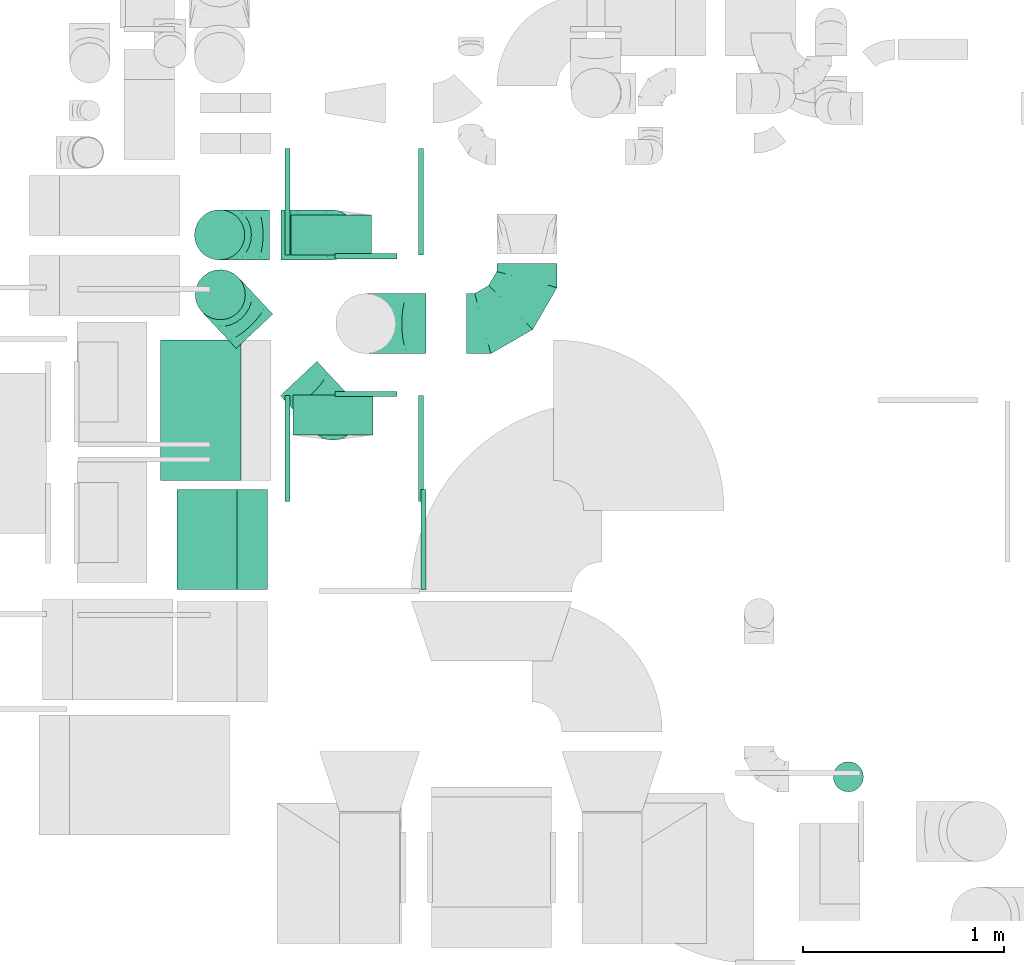
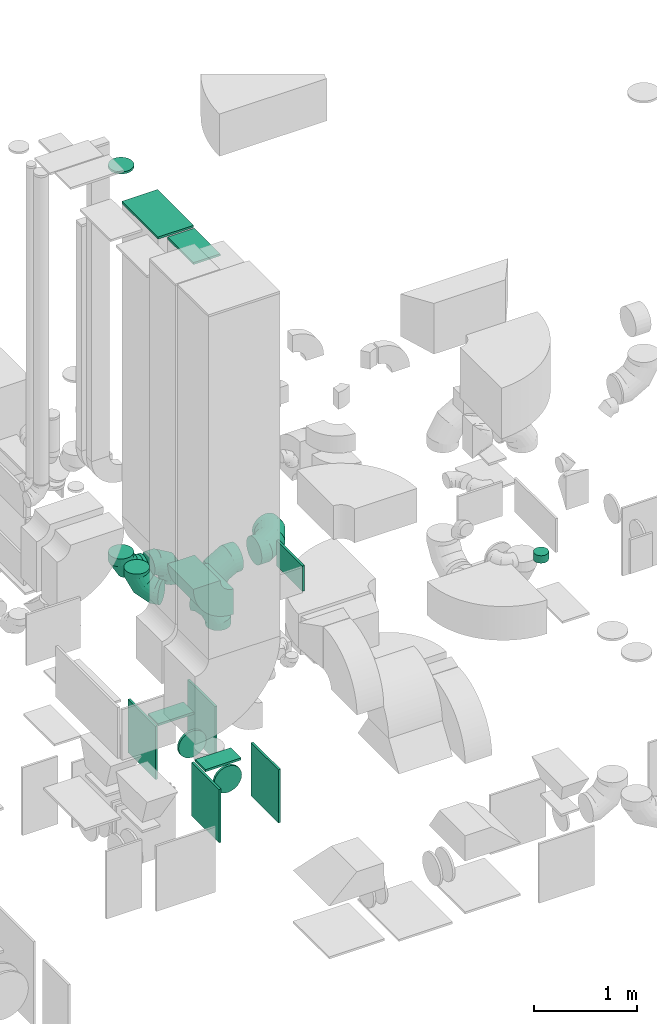
# One storey, part 21 of 59: 20 flow fittings.
"""IFC2X3 building model written with IfcOpenShell, lengths in millimetres."""

import ifcopenshell
import ifcopenshell.guid

model = None  # the IFC model being written
_history = None  # IfcOwnerHistory: only IFC2X3 demands one
_inside = {}  # id of a spatial element -> (the spatial element, [elements in it])
_under = {}  # id of a project, library or spatial element -> (it, [spatial elements below it])
_declared = {}  # id of a project -> (the project, [libraries it declares])
_typed = {}  # id of a type object -> (the type object, [elements of that type])
_made_of = {}  # id of a material, layer set ... -> (it, [elements and type objects made of it])


def new_model(schema):
    """Start an empty IFC model of exactly this schema.

    Asked for "IFC4X3", IfcOpenShell would pick the latest addendum, in which some entities
    have other attributes; the version numbers below select the first issue.
    IFC2X3 requires an IfcOwnerHistory on every rooted entity: one is made here for all.
    """
    global model, _history
    if schema == "IFC4X3":
        model = ifcopenshell.file(schema_version=(4, 3, 0, 0))
    else:
        model = ifcopenshell.file(schema=schema)
    _inside.clear()
    _under.clear()
    _declared.clear()
    _typed.clear()
    _made_of.clear()
    _history = None
    if model.schema == "IFC2X3":
        org = make("IfcOrganization", Name="unknown")
        user = make(
            "IfcPersonAndOrganization",
            ThePerson=make("IfcPerson", FamilyName="unknown"),
            TheOrganization=org,
        )
        app = make(
            "IfcApplication",
            ApplicationDeveloper=org,
            Version="unknown",
            ApplicationFullName="unknown",
            ApplicationIdentifier="unknown",
        )
        _history = make(
            "IfcOwnerHistory",
            OwningUser=user,
            OwningApplication=app,
            ChangeAction="ADDED",
            CreationDate=0,
        )
    return model


def make(cls, **values):
    """One entity of the class cls with the attributes given. An attribute that is None is left unset."""
    return model.create_entity(
        cls, **{name: value for name, value in values.items() if value is not None}
    )


def entity(cls, *values):
    """Any entity or typed value of the class cls, its attributes in the order of the schema. None: left unset."""
    e = model.create_entity(cls)
    for i, value in enumerate(values):
        if value is not None:
            e[i] = value
    return e


def rooted(cls, **values):
    """An entity with a GlobalId (a new one), such as an element, a storey or a relation."""
    return make(cls, GlobalId=ifcopenshell.guid.new(), OwnerHistory=_history, **values)


def si_unit(unit_type, name, prefix=None):
    """IfcSIUnit, for example si_unit("LENGTHUNIT", "METRE", prefix="MILLI")."""
    return make("IfcSIUnit", UnitType=unit_type, Prefix=prefix, Name=name)


def converted_unit(unit_type, name, factor, base, dimensions=None, offset=None):
    """IfcConversionBasedUnit, such as the inch: factor (a typed value) times the base unit."""
    return make(
        "IfcConversionBasedUnit"
        if offset is None
        else "IfcConversionBasedUnitWithOffset",
        ConversionOffset=offset,
        Dimensions=None
        if dimensions is None
        else entity("IfcDimensionalExponents", *dimensions),
        UnitType=unit_type,
        Name=name,
        ConversionFactor=make(
            "IfcMeasureWithUnit", ValueComponent=factor, UnitComponent=base
        ),
    )


def derived_unit(unit_type, elements):
    """IfcDerivedUnit: a product of units, each with its exponent."""
    return make(
        "IfcDerivedUnit",
        Elements=[
            make("IfcDerivedUnitElement", Unit=unit, Exponent=power)
            for unit, power in elements
        ],
        UnitType=unit_type,
    )


def assignment(units):
    """IfcUnitAssignment: the units of a project."""
    return None if units is None else make("IfcUnitAssignment", Units=units)


def point(xyz):
    """IfcCartesianPoint."""
    return None if xyz is None else make("IfcCartesianPoint", Coordinates=xyz)


def direction(xyz):
    """IfcDirection."""
    return None if xyz is None else make("IfcDirection", DirectionRatios=xyz)


def frame(location, z_axis=None, x_axis=None):
    """IfcAxis2Placement3D, a coordinate frame: its origin and axes. An axis left out is left unset."""
    return make(
        "IfcAxis2Placement3D",
        Location=point(location),
        Axis=direction(z_axis),
        RefDirection=direction(x_axis),
    )


def frame_2d(location, x_axis=None):
    """IfcAxis2Placement2D, a coordinate frame in the plane: its origin and x axis."""
    return make(
        "IfcAxis2Placement2D", Location=point(location), RefDirection=direction(x_axis)
    )


def origin():
    """The frame at (0, 0, 0) with its axes left unset."""
    return frame((0.0, 0.0, 0.0))


def origin_2d_with_axis():
    """The frame at (0, 0) in the plane with the x axis (1, 0) written out."""
    return frame_2d((0.0, 0.0), x_axis=(1.0, 0.0))


def place(relative_to, where):
    """IfcLocalPlacement: puts the frame where relative to a parent placement (None: the world)."""
    return make(
        "IfcLocalPlacement", PlacementRelTo=relative_to, RelativePlacement=where
    )


def context(
    kind, dimensions, precision=None, world=None, true_north=None, identifier=None
):
    """IfcGeometricRepresentationContext, for example the 3D "Model" context."""
    return make(
        "IfcGeometricRepresentationContext",
        ContextIdentifier=identifier,
        ContextType=kind,
        CoordinateSpaceDimension=dimensions,
        Precision=precision,
        WorldCoordinateSystem=world,
        TrueNorth=true_north,
    )


def subcontext(parent, identifier, kind, view, scale=None):
    """IfcGeometricRepresentationSubContext, for example "Body" below "Model"."""
    return make(
        "IfcGeometricRepresentationSubContext",
        ContextIdentifier=identifier,
        ContextType=kind,
        ParentContext=parent,
        TargetScale=scale,
        TargetView=view,
    )


def project(units=None, contexts=None):
    """IfcProject with its units and contexts."""
    return rooted(
        "IfcProject",
        Name="project",
        RepresentationContexts=contexts,
        UnitsInContext=assignment(units),
    )


def spatial(cls, under=None, at=None, **own):
    """A site, building, storey or space (cls), placed at a placement, below another one or the project."""
    s = rooted(cls, ObjectPlacement=at, **own)
    if under is not None:
        _under.setdefault(under.id(), (under, []))[1].append(s)
    return s


def polyline(points):
    """IfcPolyline through the points."""
    return make("IfcPolyline", Points=[point(p) for p in points])


def circle_curve(where, radius):
    """IfcCircle in the frame where."""
    return make("IfcCircle", Position=where, Radius=radius)


def parameter(value):
    """IfcParameterValue: where a trimmed curve begins or ends, as a parameter of its basis curve."""
    return model.create_entity("IfcParameterValue", value)


def trimmed(basis, trim1, trim2, sense, master):
    """IfcTrimmedCurve: the piece of a basis curve between two trims."""
    return make(
        "IfcTrimmedCurve",
        BasisCurve=basis,
        Trim1=trim1,
        Trim2=trim2,
        SenseAgreement=sense,
        MasterRepresentation=master,
    )


def segment(curve, same_sense, transition):
    """IfcCompositeCurveSegment."""
    return make(
        "IfcCompositeCurveSegment",
        Transition=transition,
        SameSense=same_sense,
        ParentCurve=curve,
    )


def composite_curve(segments, self_intersect=None):
    """IfcCompositeCurve: segments joined end to end."""
    return make("IfcCompositeCurve", Segments=segments, SelfIntersect=self_intersect)


def profile(cls, at=None, kind="AREA", **sizes):
    """A parametric profile (cls). Its sizes go by their IFC names, for example OverallWidth=200.0."""
    return make(cls, ProfileType=kind, Position=at, **sizes)


def rectangle(**sizes):
    """IfcRectangleProfileDef."""
    return profile("IfcRectangleProfileDef", **sizes)


def circle(**sizes):
    """IfcCircleProfileDef."""
    return profile("IfcCircleProfileDef", **sizes)


def outline(outer, holes=None, kind="AREA"):
    """IfcArbitraryClosedProfileDef: a profile drawn as a closed curve; with holes, ...WithVoids."""
    if holes is None:
        return make("IfcArbitraryClosedProfileDef", ProfileType=kind, OuterCurve=outer)
    return make(
        "IfcArbitraryProfileDefWithVoids",
        ProfileType=kind,
        OuterCurve=outer,
        InnerCurves=holes,
    )


def extrude(swept, where, along, depth):
    """IfcExtrudedAreaSolid: the profile swept, set in the frame where, extruded along a direction by depth."""
    return make(
        "IfcExtrudedAreaSolid",
        SweptArea=swept,
        Position=where,
        ExtrudedDirection=direction(along),
        Depth=depth,
    )


def faces_of(points, faces, orient=None, outer=None):
    """IfcFace entities. A face is a list of loops; a loop is a list of indices into points, from 0.

    orient and outer hold one flag for each loop. By default every Orientation is true, the
    first loop of a face is its IfcFaceOuterBound and the others are IfcFaceBound.
    """
    made = []
    for i, loops in enumerate(faces):
        bounds = []
        for j, loop in enumerate(loops):
            is_outer = j == 0 if outer is None else outer[i][j]
            bounds.append(
                make(
                    "IfcFaceOuterBound" if is_outer else "IfcFaceBound",
                    Bound=make("IfcPolyLoop", Polygon=[points[k] for k in loop]),
                    Orientation=True if orient is None else orient[i][j],
                )
            )
        made.append(make("IfcFace", Bounds=bounds))
    return made


def faceted_brep(points, faces, orient=None, outer=None, voids=None):
    """IfcFacetedBrep: a solid bounded by flat faces; with voids (closed shells), ...WithVoids."""
    shared = [point(p) for p in points]
    hull = make("IfcClosedShell", CfsFaces=faces_of(shared, faces, orient, outer))
    if voids is None:
        return make("IfcFacetedBrep", Outer=hull)
    return make(
        "IfcFacetedBrepWithVoids",
        Outer=hull,
        Voids=[
            make(cls, CfsFaces=faces_of(shared, fs, o, b)) for cls, fs, o, b in voids
        ],
    )


def shape(context_of_items, identifier, shape_type, items):
    """IfcShapeRepresentation: the items that make up one representation, for example the "Body"."""
    return make(
        "IfcShapeRepresentation",
        ContextOfItems=context_of_items,
        RepresentationIdentifier=identifier,
        RepresentationType=shape_type,
        Items=items,
    )


def source(mapping_origin, context_of_items, identifier, shape_type, items):
    """IfcRepresentationMap: a shape defined once, which mapped items show again and again."""
    return make(
        "IfcRepresentationMap",
        MappingOrigin=mapping_origin,
        MappedRepresentation=shape(context_of_items, identifier, shape_type, items),
    )


def transform(
    local_origin,
    x_axis=None,
    y_axis=None,
    z_axis=None,
    scale=None,
    scale2=None,
    scale3=None,
    uniform=True,
):
    """IfcCartesianTransformationOperator3D, or its non-uniform kind. x_axis, y_axis, z_axis: its Axis1, 2, 3."""
    if uniform:
        return make(
            "IfcCartesianTransformationOperator3D",
            Axis1=direction(x_axis),
            Axis2=direction(y_axis),
            LocalOrigin=point(local_origin),
            Scale=scale,
            Axis3=direction(z_axis),
        )
    return make(
        "IfcCartesianTransformationOperator3DnonUniform",
        Axis1=direction(x_axis),
        Axis2=direction(y_axis),
        LocalOrigin=point(local_origin),
        Scale=scale,
        Axis3=direction(z_axis),
        Scale2=scale2,
        Scale3=scale3,
    )


def mapped(mapping_source, mapping_target):
    """IfcMappedItem: shows the shape of a source again, moved by a transform."""
    return make(
        "IfcMappedItem", MappingSource=mapping_source, MappingTarget=mapping_target
    )


def material(Name=None, Category=None):
    """IfcMaterial."""
    return make("IfcMaterial", Name=Name, Category=Category)


def made_of(thing, what):
    """Note that an element or type object is made of a material, layer set ...; save() writes the relation."""
    if what is not None:
        _made_of.setdefault(what.id(), (what, []))[1].append(thing)
    return thing


def type_object(cls, material=None, **own):
    """A type object (cls), such as IfcWallType, which elements share."""
    return made_of(rooted(cls, **own), material)


def type_shapes(of_type, sources):
    """Give a type object the sources (RepresentationMaps) that its elements show as mapped items."""
    of_type.RepresentationMaps = sources


def element(
    cls,
    number,
    at=None,
    inside=None,
    cuts=None,
    type_object=None,
    material=None,
    context=None,
    identifier="Body",
    shape_type=None,
    held_by="IfcProductDefinitionShape",
    body=None,
    shapes=None,
    **own,
):
    """One element of the class cls, such as IfcWall. Its Tag is "e" and its number.

    at: its placement. inside: the storey or other place that contains it. cuts: it is an
    opening in that element (IfcRelVoidsElement). A single representation is given by context,
    identifier, shape_type and body (its items); several are given by shapes. held_by: the class
    of the entity that holds the representations. save() writes the other relations.
    """
    e = rooted(cls, Tag="e%d" % number, ObjectPlacement=at, **own)
    if body is not None:
        shapes = [shape(context, identifier, shape_type, body)]
    if shapes is not None:
        e.Representation = make(held_by, Representations=shapes)
    if inside is not None:
        _inside.setdefault(inside.id(), (inside, []))[1].append(e)
    if cuts is not None:
        rooted(
            "IfcRelVoidsElement", RelatingBuildingElement=cuts, RelatedOpeningElement=e
        )
    if type_object is not None:
        _typed.setdefault(type_object.id(), (type_object, []))[1].append(e)
    return made_of(e, material)


def aggregate(whole, parts):
    """IfcRelAggregates: a whole, such as a stair, and the parts it consists of."""
    return rooted("IfcRelAggregates", RelatingObject=whole, RelatedObjects=parts)


def save(model, path):
    """Write the relations noted so far, then the file.

    IfcRelAggregates (storeys below a building ...), IfcRelContainedInSpatialStructure (elements
    in a storey), IfcRelDefinesByType, IfcRelAssociatesMaterial and IfcRelDeclares: one each for
    every whole, place, type object, material and project.
    """
    for whole, parts in _under.values():
        aggregate(whole, parts)
    for where, things in _inside.values():
        rooted(
            "IfcRelContainedInSpatialStructure",
            RelatedElements=things,
            RelatingStructure=where,
        )
    for kind, things in _typed.values():
        rooted("IfcRelDefinesByType", RelatedObjects=things, RelatingType=kind)
    for what, things in _made_of.values():
        rooted("IfcRelAssociatesMaterial", RelatedObjects=things, RelatingMaterial=what)
    for by, libraries in _declared.values():
        rooted("IfcRelDeclares", RelatingContext=by, RelatedDefinitions=libraries)
    model.write(path)


model = new_model("IFC2X3")

# Units and contexts
model_context = context("Model", 3, precision=0.01, world=origin(), true_north=direction((6.12303176911189e-17, 1.0)))
body_context = subcontext(model_context, "Body", "Model", "MODEL_VIEW")
ifc_project = project(units=[si_unit("LENGTHUNIT", "METRE", prefix="MILLI"), si_unit("AREAUNIT", "SQUARE_METRE"), si_unit("VOLUMEUNIT", "CUBIC_METRE"), converted_unit("PLANEANGLEUNIT", "DEGREE", entity("IfcRatioMeasure", 0.0174532925199433), si_unit("PLANEANGLEUNIT", "RADIAN"), dimensions=[0, 0, 0, 0, 0, 0, 0]), si_unit("MASSUNIT", "GRAM", prefix="KILO"), derived_unit("MASSDENSITYUNIT", [(si_unit("MASSUNIT", "GRAM", prefix="KILO"), 1), (si_unit("LENGTHUNIT", "METRE"), -3)]), derived_unit("MOMENTOFINERTIAUNIT", [(si_unit("LENGTHUNIT", "METRE"), 4)]), si_unit("TIMEUNIT", "SECOND"), si_unit("FREQUENCYUNIT", "HERTZ"), si_unit("THERMODYNAMICTEMPERATUREUNIT", "DEGREE_CELSIUS"), derived_unit("THERMALTRANSMITTANCEUNIT", [(si_unit("MASSUNIT", "GRAM", prefix="KILO"), 1), (si_unit("THERMODYNAMICTEMPERATUREUNIT", "KELVIN"), -1), (si_unit("TIMEUNIT", "SECOND"), -3)]), derived_unit("VOLUMETRICFLOWRATEUNIT", [(si_unit("LENGTHUNIT", "METRE"), 3), (si_unit("TIMEUNIT", "SECOND"), -1)]), derived_unit("MASSFLOWRATEUNIT", [(si_unit("MASSUNIT", "GRAM", prefix="KILO"), 1), (si_unit("TIMEUNIT", "SECOND"), -1)]), derived_unit("ROTATIONALFREQUENCYUNIT", [(si_unit("TIMEUNIT", "SECOND"), -1)]), si_unit("ELECTRICCURRENTUNIT", "AMPERE"), si_unit("ELECTRICVOLTAGEUNIT", "VOLT"), si_unit("POWERUNIT", "WATT"), si_unit("FORCEUNIT", "NEWTON", prefix="KILO"), si_unit("ILLUMINANCEUNIT", "LUX"), si_unit("LUMINOUSFLUXUNIT", "LUMEN"), si_unit("LUMINOUSINTENSITYUNIT", "CANDELA"), derived_unit("USERDEFINED", [(si_unit("MASSUNIT", "GRAM", prefix="KILO"), -1), (si_unit("LENGTHUNIT", "METRE"), -2), (si_unit("TIMEUNIT", "SECOND"), 3), (si_unit("LUMINOUSFLUXUNIT", "LUMEN"), 1)]), derived_unit("LINEARVELOCITYUNIT", [(si_unit("LENGTHUNIT", "METRE"), 1), (si_unit("TIMEUNIT", "SECOND"), -1)]), si_unit("PRESSUREUNIT", "PASCAL"), derived_unit("USERDEFINED", [(si_unit("LENGTHUNIT", "METRE"), -2), (si_unit("MASSUNIT", "GRAM", prefix="KILO"), 1), (si_unit("TIMEUNIT", "SECOND"), -2)]), derived_unit("LINEARFORCEUNIT", [(si_unit("MASSUNIT", "GRAM", prefix="KILO"), 1), (si_unit("LENGTHUNIT", "METRE"), 1), (si_unit("TIMEUNIT", "SECOND"), -2), (si_unit("LENGTHUNIT", "METRE"), -1)]), derived_unit("PLANARFORCEUNIT", [(si_unit("MASSUNIT", "GRAM", prefix="KILO"), 1), (si_unit("LENGTHUNIT", "METRE"), 1), (si_unit("TIMEUNIT", "SECOND"), -2), (si_unit("LENGTHUNIT", "METRE"), -2)])], contexts=[model_context])

# Site, building, storey
site_placement = place(None, origin())
site = spatial("IfcSite", under=ifc_project, at=site_placement, CompositionType="ELEMENT")
building_placement = place(site_placement, origin())
building = spatial("IfcBuilding", under=site, at=building_placement, CompositionType="ELEMENT")
storey_placement = place(building_placement, frame((0.0, 0.0, 28200.0)))
storey = spatial("IfcBuildingStorey", under=building, at=storey_placement, CompositionType="ELEMENT", Elevation=28200.0)

# Flow fittings
ifc_material = material()
duct_fitting_type_1 = type_object("IfcDuctFittingType", PredefinedType="NOTDEFINED", material=ifc_material)
shared_shape_1 = source(origin(), body_context, "Body", "SweptSolid", [
    extrude(rectangle(XDim=200.0, YDim=26.096, at=origin_2d_with_axis()), frame((6.95, 0.0, -200.0), z_axis=(0.0, 0.0, 1.0), x_axis=(0.0, -1.0, 0.0)), (0.0, 0.0, 1.0), 400.0),
])
type_shapes(duct_fitting_type_1, [shared_shape_1])
flow_fitting_1_placement = place(storey_placement, frame((49574.88, 11542.75, 930.0), z_axis=(1.0, 0.0, 0.0), x_axis=(0.0, 0.0, 1.0)))
element("IfcFlowFitting", 1, at=flow_fitting_1_placement, inside=storey, type_object=duct_fitting_type_1, material=ifc_material, context=body_context, shape_type="MappedRepresentation", body=[
    mapped(shared_shape_1, transform((0.0, 0.0, 0.0), scale=1.0)),
])
duct_fitting_type_2 = type_object("IfcDuctFittingType", PredefinedType="NOTDEFINED", material=ifc_material)
shared_shape_2 = source(origin(), body_context, "Body", "SweptSolid", [
    extrude(circle(Radius=124.999999999999, at=origin_2d_with_axis()), frame((0.0, 0.0, 0.0), z_axis=(1.0, 0.0, 0.0), x_axis=(0.0, 1.0, 0.0)), (0.0, 0.0, 1.0), 25.0000000000018),
])
type_shapes(duct_fitting_type_2, [shared_shape_2])
flow_fitting_2_placement = place(storey_placement, frame((49017.58, 11542.75, 7600.0), z_axis=(1.0, 0.0, 0.0), x_axis=(0.0, 0.0, 1.0)))
element("IfcFlowFitting", 2, at=flow_fitting_2_placement, inside=storey, type_object=duct_fitting_type_2, material=ifc_material, context=body_context, shape_type="MappedRepresentation", body=[
    mapped(shared_shape_2, transform((0.0, 0.0, 0.0), scale=1.0)),
])
duct_fitting_type_3 = type_object("IfcDuctFittingType", PredefinedType="NOTDEFINED", material=ifc_material)
shared_shape_3 = source(origin(), body_context, "Body", "SweptSolid", [
    extrude(rectangle(XDim=24.9999999999999, YDim=500.0, at=origin_2d_with_axis()), frame((12.5, 0.0, -150.0)), (0.0, 0.0, 1.0), 300.0),
])
type_shapes(duct_fitting_type_3, [shared_shape_3])
flow_fitting_3_placement = place(storey_placement, frame((50022.89, 10023.84, 3450.0)))
element("IfcFlowFitting", 3, at=flow_fitting_3_placement, inside=storey, type_object=duct_fitting_type_3, material=ifc_material, context=body_context, shape_type="MappedRepresentation", body=[
    mapped(shared_shape_3, transform((0.0, 0.0, 0.0), scale=1.0)),
])
flow_fitting_4_placement = place(storey_placement, frame((48955.39, 10023.84, 7587.0), z_axis=(1.0, 0.0, 0.0), x_axis=(0.0, 0.0, 1.0)))
element("IfcFlowFitting", 4, at=flow_fitting_4_placement, inside=storey, type_object=duct_fitting_type_3, material=ifc_material, context=body_context, shape_type="MappedRepresentation", body=[
    mapped(shared_shape_3, transform((0.0, 0.0, 0.0), scale=1.0)),
])
duct_fitting_type_4 = type_object("IfcDuctFittingType", PredefinedType="NOTDEFINED", material=ifc_material)
shared_shape_4 = source(origin(), body_context, "Body", "SweptSolid", [
    extrude(rectangle(XDim=26.0960000000046, YDim=200.0, at=origin_2d_with_axis()), frame((6.95, 0.0, -200.0)), (0.0, 0.0, 1.0), 400.0),
])
type_shapes(duct_fitting_type_4, [shared_shape_4])
flow_fitting_5_placement = place(storey_placement, frame((49582.71, 10643.71, 930.0), z_axis=(1.0, 0.0, 0.0), x_axis=(0.0, 0.0, 1.0)))
element("IfcFlowFitting", 5, at=flow_fitting_5_placement, inside=storey, type_object=duct_fitting_type_4, material=ifc_material, context=body_context, shape_type="MappedRepresentation", body=[
    mapped(shared_shape_4, transform((0.0, 0.0, 0.0), scale=1.0)),
])
duct_fitting_type_5 = type_object("IfcDuctFittingType", PredefinedType="NOTDEFINED", material=ifc_material)
shared_shape_5 = source(origin(), body_context, "Body", "SweptSolid", [
    extrude(rectangle(XDim=24.9999999999999, YDim=700.0, at=origin_2d_with_axis()), frame((12.5, 0.0, -200.0)), (0.0, 0.0, 1.0), 400.0),
])
type_shapes(duct_fitting_type_5, [shared_shape_5])
flow_fitting_6_placement = place(storey_placement, frame((48923.28, 10668.92, 7587.0), z_axis=(1.0, 0.0, 0.0), x_axis=(0.0, 0.0, 1.0)))
element("IfcFlowFitting", 6, at=flow_fitting_6_placement, inside=storey, type_object=duct_fitting_type_5, material=ifc_material, context=body_context, shape_type="MappedRepresentation", body=[
    mapped(shared_shape_5, transform((0.0, 0.0, 0.0), scale=1.0)),
])
duct_fitting_type_6 = type_object("IfcDuctFittingType", PredefinedType="NOTDEFINED", material=ifc_material)
shared_shape_6 = source(origin(), body_context, "Body", "SweptSolid", [
    extrude(rectangle(XDim=24.9999999999999, YDim=530.0, at=origin_2d_with_axis()), frame((12.5, 0.0, -315.0)), (0.0, 0.0, 1.0), 630.0),
])
type_shapes(duct_fitting_type_6, [shared_shape_6])
flow_fitting_7_placement = place(storey_placement, frame((50009.18, 10477.75, 615.0)))
element("IfcFlowFitting", 7, at=flow_fitting_7_placement, inside=storey, type_object=duct_fitting_type_6, material=ifc_material, context=body_context, shape_type="MappedRepresentation", body=[
    mapped(shared_shape_6, transform((0.0, 0.0, 0.0), scale=1.0)),
])
flow_fitting_8_placement = place(storey_placement, frame((49369.18, 10477.75, 615.0), z_axis=(0.0, 0.0, 1.0), x_axis=(-1.0, 0.0, 0.0)))
element("IfcFlowFitting", 8, at=flow_fitting_8_placement, inside=storey, type_object=duct_fitting_type_6, material=ifc_material, context=body_context, shape_type="MappedRepresentation", body=[
    mapped(shared_shape_6, transform((0.0, 0.0, 0.0), scale=1.0)),
])
flow_fitting_9_placement = place(storey_placement, frame((50009.18, 11707.75, 615.0)))
element("IfcFlowFitting", 9, at=flow_fitting_9_placement, inside=storey, type_object=duct_fitting_type_6, material=ifc_material, context=body_context, shape_type="MappedRepresentation", body=[
    mapped(shared_shape_6, transform((0.0, 0.0, 0.0), scale=1.0)),
])
flow_fitting_10_placement = place(storey_placement, frame((49369.18, 11707.75, 615.0), z_axis=(0.0, 0.0, 1.0), x_axis=(-1.0, 0.0, 0.0)))
element("IfcFlowFitting", 10, at=flow_fitting_10_placement, inside=storey, type_object=duct_fitting_type_6, material=ifc_material, context=body_context, shape_type="MappedRepresentation", body=[
    mapped(shared_shape_6, transform((0.0, 0.0, 0.0), scale=1.0)),
])
duct_fitting_type_7 = type_object("IfcDuctFittingType", PredefinedType="NOTDEFINED", material=ifc_material)
shared_shape_7 = source(origin(), body_context, "Body", "Brep", [
    faceted_brep([(-250.0, 0.0, -125.0), (-250.0, -32.35, -120.74), (-250.0, -62.5, -108.25), (-250.0, -88.39, -88.39), (-250.0, -108.25, -62.5), (-250.0, -120.74, -32.35), (-250.0, -125.0, 0.0), (-250.0, -120.74, 32.35), (-250.0, -108.25, 62.5), (-250.0, -88.39, 88.39), (-250.0, -62.5, 108.25), (-250.0, -32.35, 120.74), (-250.0, 0.0, 125.0), (-250.0, 32.35, 120.74), (-250.0, 62.5, 108.25), (-250.0, 88.39, 88.39), (-250.0, 108.25, 62.5), (-250.0, 120.74, 32.35), (-250.0, 125.0, 0.0), (-250.0, 120.74, -32.35), (-250.0, 108.25, -62.5), (-250.0, 88.39, -88.39), (-250.0, 62.5, -108.25), (-250.0, 32.35, -120.74), (-191.68, 32.35, 120.74), (-199.76, 62.5, 108.25), (-183.01, 0.0, 125.0), (-206.7, 88.39, 88.39), (-215.37, 120.74, 32.35), (-216.51, 125.0, 0.0), (-212.02, 108.25, 62.5), (-212.02, 108.25, -62.5), (-206.7, 88.39, -88.39), (-215.37, 120.74, -32.35), (-191.68, 32.35, -120.74), (-183.01, 0.0, -125.0), (-199.76, 62.5, -108.25), (-174.34, -32.35, -120.74), (-166.27, -62.5, -108.25), (-159.33, -88.39, -88.39), (-154.01, -108.25, -62.5), (-150.66, -120.74, -32.35), (-149.52, -125.0, 0.0), (-150.66, -120.74, 32.35), (-154.01, -108.25, 62.5), (-159.33, -88.39, 88.39), (-166.27, -62.5, 108.25), (-174.34, -32.35, 120.74), (-90.67, 90.67, 120.74), (-112.74, 112.74, 108.25), (-66.99, 66.99, 125.0), (-131.69, 131.69, 88.39), (-146.23, 146.23, 62.5), (-155.38, 155.38, 32.35), (-158.49, 158.49, 0.0), (-155.38, 155.38, -32.35), (-146.23, 146.23, -62.5), (-131.69, 131.69, -88.39), (-90.67, 90.67, -120.74), (-66.99, 66.99, -125.0), (-112.74, 112.74, -108.25), (-43.3, 43.3, -120.74), (-21.23, 21.23, -108.25), (-2.28, 2.28, -88.39), (12.26, -12.26, -62.5), (21.4, -21.4, -32.35), (24.52, -24.52, 0.0), (21.4, -21.4, 32.35), (12.26, -12.26, 62.5), (-2.28, 2.28, 88.39), (-21.23, 21.23, 108.25), (-43.3, 43.3, 120.74), (-32.35, 191.68, 120.74), (-62.5, 199.76, 108.25), (0.0, 183.01, 125.0), (-88.39, 206.7, 88.39), (-108.25, 212.02, 62.5), (-120.74, 215.37, 32.35), (-125.0, 216.51, 0.0), (-120.74, 215.37, -32.35), (-108.25, 212.02, -62.5), (-88.39, 206.7, -88.39), (-32.35, 191.68, -120.74), (0.0, 183.01, -125.0), (-62.5, 199.76, -108.25), (32.35, 174.34, -120.74), (62.5, 166.27, -108.25), (88.39, 159.33, -88.39), (108.25, 154.01, -62.5), (120.74, 150.66, -32.35), (125.0, 149.52, 0.0), (120.74, 150.66, 32.35), (108.25, 154.01, 62.5), (88.39, 159.33, 88.39), (62.5, 166.27, 108.25), (32.35, 174.34, 120.74), (-32.35, 250.0, -120.74), (-62.5, 250.0, -108.25), (-88.39, 250.0, -88.39), (-108.25, 250.0, -62.5), (-120.74, 250.0, -32.35), (-125.0, 250.0, 0.0), (-120.74, 250.0, 32.35), (-108.25, 250.0, 62.5), (-88.39, 250.0, 88.39), (-62.5, 250.0, 108.25), (-32.35, 250.0, 120.74), (0.0, 250.0, 125.0), (32.35, 250.0, 120.74), (62.5, 250.0, 108.25), (88.39, 250.0, 88.39), (108.25, 250.0, 62.5), (120.74, 250.0, 32.35), (125.0, 250.0, 0.0), (120.74, 250.0, -32.35), (108.25, 250.0, -62.5), (88.39, 250.0, -88.39), (62.5, 250.0, -108.25), (32.35, 250.0, -120.74), (0.0, 250.0, -125.0)], [[[0, 1, 2, 3, 4, 5, 6, 7, 8, 9, 10, 11, 12, 13, 14, 15, 16, 17, 18, 19, 20, 21, 22, 23]], [[24, 25, 14, 13]], [[26, 24, 13, 12]], [[14, 25, 27, 15]], [[28, 29, 18, 17]], [[30, 28, 17, 16]], [[15, 27, 30, 16]], [[20, 31, 32, 21]], [[33, 31, 20, 19]], [[18, 29, 33, 19]], [[34, 35, 0, 23]], [[36, 34, 23, 22]], [[21, 32, 36, 22]], [[1, 0, 35, 37]], [[2, 1, 37, 38]], [[38, 39, 3, 2]], [[5, 4, 40, 41]], [[6, 5, 41, 42]], [[39, 40, 4, 3]], [[6, 42, 43, 7]], [[7, 43, 44, 8]], [[8, 44, 45, 9]], [[9, 45, 46, 10]], [[10, 46, 47, 11]], [[26, 12, 11, 47]], [[48, 49, 25, 24]], [[50, 48, 24, 26]], [[27, 25, 49, 51]], [[52, 53, 28, 30]], [[51, 52, 30, 27]], [[29, 28, 53, 54]], [[55, 56, 31, 33]], [[54, 55, 33, 29]], [[32, 31, 56, 57]], [[58, 59, 35, 34]], [[60, 58, 34, 36]], [[57, 60, 36, 32]], [[37, 35, 59, 61]], [[38, 37, 61, 62]], [[39, 38, 62, 63]], [[41, 40, 64, 65]], [[42, 41, 65, 66]], [[63, 64, 40, 39]], [[43, 42, 66, 67]], [[44, 43, 67, 68]], [[68, 69, 45, 44]], [[46, 45, 69, 70]], [[47, 46, 70, 71]], [[26, 47, 71, 50]], [[72, 73, 49, 48]], [[74, 72, 48, 50]], [[51, 49, 73, 75]], [[76, 77, 53, 52]], [[75, 76, 52, 51]], [[54, 53, 77, 78]], [[79, 80, 56, 55]], [[78, 79, 55, 54]], [[57, 56, 80, 81]], [[82, 83, 59, 58]], [[84, 82, 58, 60]], [[81, 84, 60, 57]], [[61, 59, 83, 85]], [[62, 61, 85, 86]], [[63, 62, 86, 87]], [[65, 64, 88, 89]], [[66, 65, 89, 90]], [[87, 88, 64, 63]], [[67, 66, 90, 91]], [[68, 67, 91, 92]], [[92, 93, 69, 68]], [[70, 69, 93, 94]], [[71, 70, 94, 95]], [[50, 71, 95, 74]], [[96, 97, 98, 99, 100, 101, 102, 103, 104, 105, 106, 107, 108, 109, 110, 111, 112, 113, 114, 115, 116, 117, 118, 119]], [[72, 74, 107, 106]], [[73, 72, 106, 105]], [[75, 73, 105, 104]], [[77, 76, 103, 102]], [[78, 77, 102, 101]], [[75, 104, 103, 76]], [[78, 101, 100, 79]], [[79, 100, 99, 80]], [[80, 99, 98, 81]], [[84, 97, 96, 82]], [[82, 96, 119, 83]], [[84, 81, 98, 97]], [[83, 119, 118, 85]], [[85, 118, 117, 86]], [[116, 87, 86, 117]], [[88, 115, 114, 89]], [[89, 114, 113, 90]], [[115, 88, 87, 116]], [[91, 90, 113, 112]], [[92, 91, 112, 111]], [[111, 110, 93, 92]], [[95, 94, 109, 108]], [[74, 95, 108, 107]], [[110, 109, 94, 93]]]),
])
type_shapes(duct_fitting_type_7, [shared_shape_7])
for number, where, z_axis, x_axis in (
    (11, (49017.58, 11542.75, 2800.0), (0.0, -1.0, 0.0), (0.0, 0.0, -1.0)),
    (12, (49574.88, 11542.75, 2800.0), (0.0, 1.0, 0.0), (1.0, 0.0, 0.0)),
    (13, (49020.94, 11244.3, 2800.0), (-0.730316942112033, -0.683108457028698, 0.0), (0.0, 0.0, -1.0)),
    (14, (49582.71, 10643.71, 2800.0), (-0.730316942112037, -0.683108457028695, 0.0), (0.0, 0.0, 1.0)),
):
    element("IfcFlowFitting", number, at=place(storey_placement, frame(where, z_axis=z_axis, x_axis=x_axis)), inside=storey, type_object=duct_fitting_type_7, material=ifc_material, context=body_context, shape_type="MappedRepresentation", body=[
        mapped(shared_shape_7, transform((0.0, 0.0, 0.0), scale=1.0)),
    ])
duct_fitting_type_8 = type_object("IfcDuctFittingType", PredefinedType="NOTDEFINED", material=ifc_material)
shared_shape_8 = source(origin(), body_context, "Body", "Brep", [
    faceted_brep([(-300.0, 0.0, -150.0), (-300.0, -38.82, -144.89), (-300.0, -75.0, -129.9), (-300.0, -106.07, -106.07), (-300.0, -129.9, -75.0), (-300.0, -144.89, -38.82), (-300.0, -150.0, 0.0), (-300.0, -144.89, 38.82), (-300.0, -129.9, 75.0), (-300.0, -106.07, 106.07), (-300.0, -75.0, 129.9), (-300.0, -38.82, 144.89), (-300.0, 0.0, 150.0), (-300.0, 38.82, 144.89), (-300.0, 75.0, 129.9), (-300.0, 106.07, 106.07), (-300.0, 129.9, 75.0), (-300.0, 144.89, 38.82), (-300.0, 150.0, 0.0), (-300.0, 144.89, -38.82), (-300.0, 129.9, -75.0), (-300.0, 106.07, -106.07), (-300.0, 75.0, -129.9), (-300.0, 38.82, -144.89), (-230.02, 38.82, 144.89), (-239.71, 75.0, 129.9), (-219.62, 0.0, 150.0), (-248.04, 106.07, 106.07), (-258.44, 144.89, 38.82), (-259.81, 150.0, 0.0), (-254.42, 129.9, 75.0), (-254.42, 129.9, -75.0), (-248.04, 106.07, -106.07), (-258.44, 144.89, -38.82), (-230.02, 38.82, -144.89), (-219.62, 0.0, -150.0), (-239.71, 75.0, -129.9), (-209.21, -38.82, -144.89), (-199.52, -75.0, -129.9), (-191.19, -106.07, -106.07), (-184.81, -129.9, -75.0), (-180.79, -144.89, -38.82), (-179.42, -150.0, 0.0), (-180.79, -144.89, 38.82), (-184.81, -129.9, 75.0), (-191.19, -106.07, 106.07), (-199.52, -75.0, 129.9), (-209.21, -38.82, 144.89), (-108.81, 108.81, 144.89), (-135.29, 135.29, 129.9), (-80.38, 80.38, 150.0), (-158.03, 158.03, 106.07), (-175.48, 175.48, 75.0), (-186.45, 186.45, 38.82), (-190.19, 190.19, 0.0), (-186.45, 186.45, -38.82), (-175.48, 175.48, -75.0), (-158.03, 158.03, -106.07), (-108.81, 108.81, -144.89), (-80.38, 80.38, -150.0), (-135.29, 135.29, -129.9), (-51.96, 51.96, -144.89), (-25.48, 25.48, -129.9), (-2.74, 2.74, -106.07), (14.71, -14.71, -75.0), (25.68, -25.68, -38.82), (29.42, -29.42, 0.0), (25.68, -25.68, 38.82), (14.71, -14.71, 75.0), (-2.74, 2.74, 106.07), (-25.48, 25.48, 129.9), (-51.96, 51.96, 144.89), (-38.82, 230.02, 144.89), (-75.0, 239.71, 129.9), (0.0, 219.62, 150.0), (-106.07, 248.04, 106.07), (-129.9, 254.42, 75.0), (-144.89, 258.44, 38.82), (-150.0, 259.81, 0.0), (-144.89, 258.44, -38.82), (-129.9, 254.42, -75.0), (-106.07, 248.04, -106.07), (-38.82, 230.02, -144.89), (0.0, 219.62, -150.0), (-75.0, 239.71, -129.9), (38.82, 209.21, -144.89), (75.0, 199.52, -129.9), (106.07, 191.19, -106.07), (129.9, 184.81, -75.0), (144.89, 180.79, -38.82), (150.0, 179.42, 0.0), (144.89, 180.79, 38.82), (129.9, 184.81, 75.0), (106.07, 191.19, 106.07), (75.0, 199.52, 129.9), (38.82, 209.21, 144.89), (-150.0, 300.0, 0.0), (-144.89, 300.0, 38.82), (-129.9, 300.0, 75.0), (-106.07, 300.0, 106.07), (-75.0, 300.0, 129.9), (-38.82, 300.0, 144.89), (0.0, 300.0, 150.0), (38.82, 300.0, 144.89), (75.0, 300.0, 129.9), (106.07, 300.0, 106.07), (129.9, 300.0, 75.0), (144.89, 300.0, 38.82), (150.0, 300.0, 0.0), (144.89, 300.0, -38.82), (129.9, 300.0, -75.0), (106.07, 300.0, -106.07), (75.0, 300.0, -129.9), (38.82, 300.0, -144.89), (0.0, 300.0, -150.0), (-38.82, 300.0, -144.89), (-75.0, 300.0, -129.9), (-106.07, 300.0, -106.07), (-129.9, 300.0, -75.0), (-144.89, 300.0, -38.82)], [[[0, 1, 2, 3, 4, 5, 6, 7, 8, 9, 10, 11, 12, 13, 14, 15, 16, 17, 18, 19, 20, 21, 22, 23]], [[24, 25, 14, 13]], [[26, 24, 13, 12]], [[14, 25, 27, 15]], [[28, 29, 18, 17]], [[30, 28, 17, 16]], [[15, 27, 30, 16]], [[20, 31, 32, 21]], [[33, 31, 20, 19]], [[18, 29, 33, 19]], [[34, 35, 0, 23]], [[36, 34, 23, 22]], [[32, 36, 22, 21]], [[1, 0, 35, 37]], [[2, 1, 37, 38]], [[38, 39, 3, 2]], [[5, 4, 40, 41]], [[6, 5, 41, 42]], [[39, 40, 4, 3]], [[6, 42, 43, 7]], [[7, 43, 44, 8]], [[8, 44, 45, 9]], [[9, 45, 46, 10]], [[10, 46, 47, 11]], [[26, 12, 11, 47]], [[48, 49, 25, 24]], [[50, 48, 24, 26]], [[27, 25, 49, 51]], [[52, 53, 28, 30]], [[51, 52, 30, 27]], [[29, 28, 53, 54]], [[55, 56, 31, 33]], [[54, 55, 33, 29]], [[32, 31, 56, 57]], [[58, 59, 35, 34]], [[60, 58, 34, 36]], [[57, 60, 36, 32]], [[37, 35, 59, 61]], [[38, 37, 61, 62]], [[39, 38, 62, 63]], [[41, 40, 64, 65]], [[42, 41, 65, 66]], [[63, 64, 40, 39]], [[43, 42, 66, 67]], [[44, 43, 67, 68]], [[68, 69, 45, 44]], [[46, 45, 69, 70]], [[47, 46, 70, 71]], [[26, 47, 71, 50]], [[72, 73, 49, 48]], [[74, 72, 48, 50]], [[51, 49, 73, 75]], [[76, 77, 53, 52]], [[75, 76, 52, 51]], [[54, 53, 77, 78]], [[79, 80, 56, 55]], [[78, 79, 55, 54]], [[57, 56, 80, 81]], [[82, 83, 59, 58]], [[84, 82, 58, 60]], [[81, 84, 60, 57]], [[61, 59, 83, 85]], [[62, 61, 85, 86]], [[63, 62, 86, 87]], [[65, 64, 88, 89]], [[66, 65, 89, 90]], [[87, 88, 64, 63]], [[67, 66, 90, 91]], [[68, 67, 91, 92]], [[92, 93, 69, 68]], [[70, 69, 93, 94]], [[71, 70, 94, 95]], [[50, 71, 95, 74]], [[96, 97, 98, 99, 100, 101, 102, 103, 104, 105, 106, 107, 108, 109, 110, 111, 112, 113, 114, 115, 116, 117, 118, 119]], [[101, 100, 73, 72]], [[102, 101, 72, 74]], [[75, 73, 100, 99]], [[77, 76, 98, 97]], [[78, 77, 97, 96]], [[99, 98, 76, 75]], [[119, 118, 80, 79]], [[96, 119, 79, 78]], [[117, 81, 80, 118]], [[84, 116, 115, 82]], [[82, 115, 114, 83]], [[116, 84, 81, 117]], [[83, 114, 113, 85]], [[85, 113, 112, 86]], [[111, 87, 86, 112]], [[88, 110, 109, 89]], [[89, 109, 108, 90]], [[110, 88, 87, 111]], [[91, 90, 108, 107]], [[92, 91, 107, 106]], [[106, 105, 93, 92]], [[95, 94, 104, 103]], [[74, 95, 103, 102]], [[105, 104, 94, 93]]]),
])
type_shapes(duct_fitting_type_8, [shared_shape_8])
flow_fitting_11_placement = place(storey_placement, frame((49746.88, 11100.25, 2900.0), z_axis=(0.0, 1.0, 0.0), x_axis=(0.0, 0.0, 1.0)))
element("IfcFlowFitting", 15, at=flow_fitting_11_placement, inside=storey, type_object=duct_fitting_type_8, material=ifc_material, context=body_context, shape_type="MappedRepresentation", body=[
    mapped(shared_shape_8, transform((0.0, 0.0, 0.0), scale=1.0)),
])
flow_fitting_12_placement = place(storey_placement, frame((50549.86, 11100.25, 2900.0)))
element("IfcFlowFitting", 16, at=flow_fitting_12_placement, inside=storey, type_object=duct_fitting_type_8, material=ifc_material, context=body_context, shape_type="MappedRepresentation", body=[
    mapped(shared_shape_8, transform((0.0, 0.0, 0.0), scale=1.0)),
])
duct_fitting_type_9 = type_object("IfcDuctFittingType", PredefinedType="NOTDEFINED", material=ifc_material)
shared_shape_9 = source(origin(), body_context, "Body", "Brep", [
    faceted_brep([(20.0, 40.12, -149.72), (20.0, 77.5, -134.23), (20.0, 109.6, -109.6), (20.0, 134.23, -77.5), (20.0, 149.72, -40.12), (20.0, 155.0, 0.0), (20.0, 149.72, 40.12), (20.0, 134.23, 77.5), (20.0, 109.6, 109.6), (20.0, 77.5, 134.23), (20.0, 40.12, 149.72), (20.0, 0.0, 155.0), (20.0, -40.12, 149.72), (20.0, -77.5, 134.23), (20.0, -109.6, 109.6), (20.0, -134.23, 77.5), (20.0, -149.72, 40.12), (20.0, -155.0, 0.0), (20.0, -149.72, -40.12), (20.0, -134.23, -77.5), (20.0, -109.6, -109.6), (20.0, -77.5, -134.23), (20.0, -40.12, -149.72), (20.0, 0.0, -155.0), (0.0, 0.0, 155.0), (0.0, 40.12, 149.72), (-6.1, 40.12, 149.72), (-6.1, 0.0, 155.0), (0.0, 77.5, 134.23), (-6.1, 77.5, 134.23), (0.0, 109.6, 109.6), (-6.1, 109.6, 109.6), (0.0, 134.23, 77.5), (0.0, 149.72, 40.12), (-6.1, 149.72, 40.12), (-6.1, 134.23, 77.5), (0.0, 155.0, 0.0), (-6.1, 155.0, 0.0), (0.0, 149.72, -40.12), (-6.1, 149.72, -40.12), (0.0, 134.23, -77.5), (-6.1, 134.23, -77.5), (0.0, 109.6, -109.6), (-6.1, 109.6, -109.6), (0.0, 0.0, -155.0), (-6.1, 0.0, -155.0), (-6.1, 40.12, -149.72), (0.0, 40.12, -149.72), (-6.1, 77.5, -134.23), (0.0, 77.5, -134.23), (0.0, -40.12, -149.72), (-6.1, -40.12, -149.72), (0.0, -77.5, -134.23), (-6.1, -77.5, -134.23), (0.0, -109.6, -109.6), (-6.1, -109.6, -109.6), (0.0, -134.23, -77.5), (0.0, -149.72, -40.12), (-6.1, -149.72, -40.12), (-6.1, -134.23, -77.5), (0.0, -155.0, 0.0), (-6.1, -155.0, 0.0), (0.0, -149.72, 40.12), (-6.1, -149.72, 40.12), (0.0, -134.23, 77.5), (-6.1, -134.23, 77.5), (0.0, -109.6, 109.6), (-6.1, -109.6, 109.6), (0.0, -77.5, 134.23), (0.0, -40.12, 149.72), (-6.1, -40.12, 149.72), (-6.1, -77.5, 134.23)], [[[0, 1, 2, 3, 4, 5, 6, 7, 8, 9, 10, 11, 12, 13, 14, 15, 16, 17, 18, 19, 20, 21, 22, 23]], [[24, 11, 10, 25, 26, 27]], [[25, 10, 9, 28, 29, 26]], [[28, 9, 8, 30, 31, 29]], [[32, 7, 6, 33, 34, 35]], [[33, 6, 5, 36, 37, 34]], [[30, 8, 7, 32, 35, 31]], [[36, 5, 4, 38, 39, 37]], [[38, 4, 3, 40, 41, 39]], [[40, 3, 2, 42, 43, 41]], [[0, 23, 44, 45, 46, 47]], [[1, 0, 47, 46, 48, 49]], [[49, 48, 43, 42, 2, 1]], [[44, 23, 22, 50, 51, 45]], [[50, 22, 21, 52, 53, 51]], [[52, 21, 20, 54, 55, 53]], [[56, 19, 18, 57, 58, 59]], [[57, 18, 17, 60, 61, 58]], [[54, 20, 19, 56, 59, 55]], [[60, 17, 16, 62, 63, 61]], [[62, 16, 15, 64, 65, 63]], [[64, 15, 14, 66, 67, 65]], [[68, 13, 12, 69, 70, 71]], [[69, 12, 11, 24, 27, 70]], [[66, 14, 13, 68, 71, 67]], [[45, 51, 53, 55, 59, 58, 61, 63, 65, 67, 71, 70, 27, 26, 29, 31, 35, 34, 37, 39, 41, 43, 48, 46]]]),
])
type_shapes(duct_fitting_type_9, [shared_shape_9])
for number, where, z_axis, x_axis in (
    (17, (49746.88, 11442.75, 592.5), (0.0, 0.0, 1.0), (0.0, -1.0, 0.0)),
    (18, (49746.88, 10742.75, 592.5), (0.0, 0.0, -1.0), (0.0, 1.0, 0.0)),
):
    element("IfcFlowFitting", number, at=place(storey_placement, frame(where, z_axis=z_axis, x_axis=x_axis)), inside=storey, type_object=duct_fitting_type_9, material=ifc_material, context=body_context, shape_type="MappedRepresentation", body=[
        mapped(shared_shape_9, transform((0.0, 0.0, 0.0), scale=1.0)),
    ])
duct_fitting_type_10 = type_object("IfcDuctFittingType", PredefinedType="NOTDEFINED", material=ifc_material)
shared_shape_10 = source(origin(), body_context, "Body", "Brep", [
    faceted_brep([(20.0, 19.41, -72.44), (20.0, 37.5, -64.95), (20.0, 53.03, -53.03), (20.0, 64.95, -37.5), (20.0, 72.44, -19.41), (20.0, 75.0, 0.0), (20.0, 72.44, 19.41), (20.0, 64.95, 37.5), (20.0, 53.03, 53.03), (20.0, 37.5, 64.95), (20.0, 19.41, 72.44), (20.0, 0.0, 75.0), (20.0, -19.41, 72.44), (20.0, -37.5, 64.95), (20.0, -53.03, 53.03), (20.0, -64.95, 37.5), (20.0, -72.44, 19.41), (20.0, -75.0, 0.0), (20.0, -72.44, -19.41), (20.0, -64.95, -37.5), (20.0, -53.03, -53.03), (20.0, -37.5, -64.95), (20.0, -19.41, -72.44), (20.0, 0.0, -75.0), (0.0, 0.0, 75.0), (0.0, 19.41, 72.44), (-68.9, 19.41, 72.44), (-68.9, 0.0, 75.0), (0.0, 37.5, 64.95), (-68.9, 37.5, 64.95), (0.0, 53.03, 53.03), (-68.9, 53.03, 53.03), (0.0, 64.95, 37.5), (0.0, 72.44, 19.41), (-68.9, 72.44, 19.41), (-68.9, 64.95, 37.5), (0.0, 75.0, 0.0), (-68.9, 75.0, 0.0), (0.0, 72.44, -19.41), (-68.9, 72.44, -19.41), (0.0, 64.95, -37.5), (-68.9, 64.95, -37.5), (0.0, 53.03, -53.03), (-68.9, 53.03, -53.03), (0.0, 37.5, -64.95), (0.0, 19.41, -72.44), (-68.9, 19.41, -72.44), (-68.9, 37.5, -64.95), (0.0, 0.0, -75.0), (-68.9, 0.0, -75.0), (0.0, -19.41, -72.44), (-68.9, -19.41, -72.44), (0.0, -37.5, -64.95), (-68.9, -37.5, -64.95), (0.0, -53.03, -53.03), (-68.9, -53.03, -53.03), (0.0, -64.95, -37.5), (0.0, -72.44, -19.41), (-68.9, -72.44, -19.41), (-68.9, -64.95, -37.5), (0.0, -75.0, 0.0), (-68.9, -75.0, 0.0), (0.0, -72.44, 19.41), (-68.9, -72.44, 19.41), (0.0, -64.95, 37.5), (-68.9, -64.95, 37.5), (0.0, -53.03, 53.03), (-68.9, -53.03, 53.03), (0.0, -37.5, 64.95), (0.0, -19.41, 72.44), (-68.9, -19.41, 72.44), (-68.9, -37.5, 64.95)], [[[0, 1, 2, 3, 4, 5, 6, 7, 8, 9, 10, 11, 12, 13, 14, 15, 16, 17, 18, 19, 20, 21, 22, 23]], [[24, 11, 10, 25, 26, 27]], [[25, 10, 9, 28, 29, 26]], [[28, 9, 8, 30, 31, 29]], [[32, 7, 6, 33, 34, 35]], [[33, 6, 5, 36, 37, 34]], [[30, 8, 7, 32, 35, 31]], [[36, 5, 4, 38, 39, 37]], [[38, 4, 3, 40, 41, 39]], [[40, 3, 2, 42, 43, 41]], [[44, 1, 0, 45, 46, 47]], [[48, 49, 46, 45, 0, 23]], [[42, 2, 1, 44, 47, 43]], [[48, 23, 22, 50, 51, 49]], [[50, 22, 21, 52, 53, 51]], [[52, 21, 20, 54, 55, 53]], [[56, 19, 18, 57, 58, 59]], [[57, 18, 17, 60, 61, 58]], [[54, 20, 19, 56, 59, 55]], [[60, 17, 16, 62, 63, 61]], [[62, 16, 15, 64, 65, 63]], [[64, 15, 14, 66, 67, 65]], [[68, 13, 12, 69, 70, 71]], [[69, 12, 11, 24, 27, 70]], [[66, 14, 13, 68, 71, 67]], [[49, 51, 53, 55, 59, 58, 61, 63, 65, 67, 71, 70, 27, 26, 29, 31, 35, 34, 37, 39, 41, 43, 47, 46]]]),
])
type_shapes(duct_fitting_type_10, [shared_shape_10])
flow_fitting_13_placement = place(storey_placement, frame((52153.19, 8840.5, 3525.0), z_axis=(0.0, -1.0, 0.0), x_axis=(0.0, 0.0, -1.0)))
element("IfcFlowFitting", 19, at=flow_fitting_13_placement, inside=storey, type_object=duct_fitting_type_10, material=ifc_material, context=body_context, shape_type="MappedRepresentation", body=[
    mapped(shared_shape_10, transform((0.0, 0.0, 0.0), scale=1.0)),
])
duct_fitting_type_11 = type_object("IfcDuctFittingType", PredefinedType="NOTDEFINED", material=ifc_material)
shared_shape_11 = source(origin(), body_context, "Body", "SweptSolid", [
    extrude(outline(composite_curve([segment(polyline([(-300.0, -150.0), (0.0, -150.0)]), True, "CONTINUOUS"), segment(trimmed(circle_curve(frame_2d((150.0, -150.0), x_axis=(0.0, 1.0)), 150.0), [parameter(0.0)], [parameter(90.0)], True, "PARAMETER"), False, "CONTINUOUS"), segment(polyline([(150.0, 0.0), (150.0, 300.0)]), True, "CONTINUOUS"), segment(trimmed(circle_curve(frame_2d((150.0, -150.0), x_axis=(0.0, 1.0)), 450.0), [parameter(0.0)], [parameter(90.0000000000001)], True, "PARAMETER"), True, "CONTINUOUS")], self_intersect=False)), frame((-150.0, 150.0, -250.0), z_axis=(0.0, 0.0, 1.0), x_axis=(-1.0, 0.0, 0.0)), (0.0, 0.0, 1.0), 500.0),
])
type_shapes(duct_fitting_type_11, [shared_shape_11])
flow_fitting_14_placement = place(storey_placement, frame((48955.39, 10023.84, 3450.0), z_axis=(0.0, 1.0, 0.0), x_axis=(-1.0, 0.0, 0.0)))
element("IfcFlowFitting", 20, at=flow_fitting_14_placement, inside=storey, type_object=duct_fitting_type_11, material=ifc_material, context=body_context, shape_type="MappedRepresentation", body=[
    mapped(shared_shape_11, transform((0.0, 0.0, 0.0), scale=1.0)),
])

save(model, "model.ifc")
